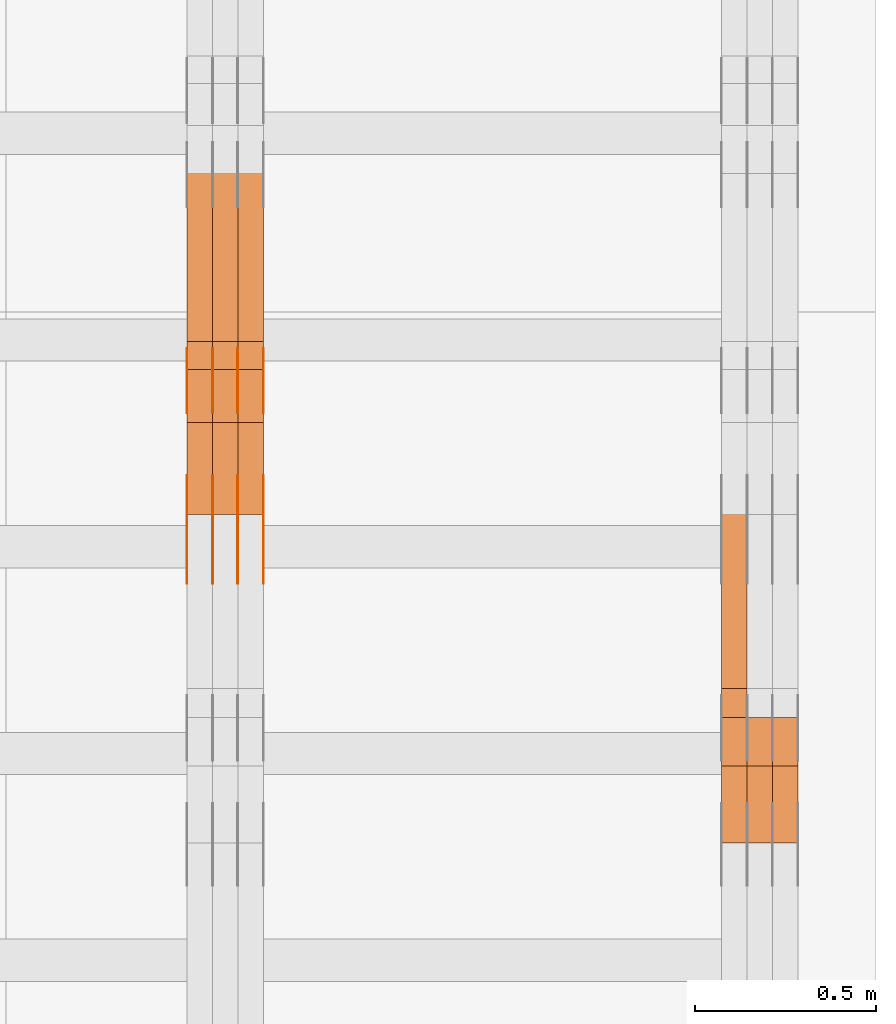
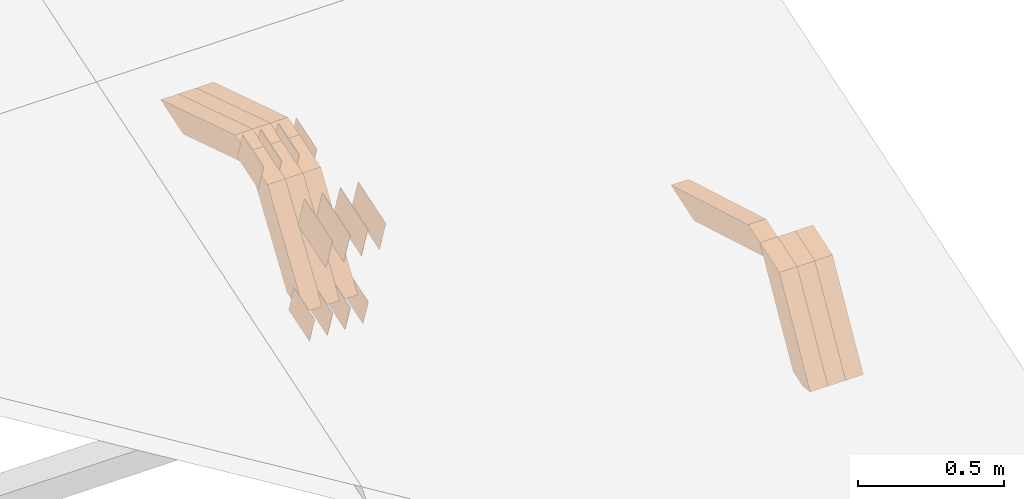
# One storey, part 309 of 385: 28 proxies.
"""IFC2X3 building model written with IfcOpenShell, lengths in millimetres."""

from ifc_helpers import new_model, entity, si_unit, converted_unit, derived_unit, direction, frame, origin, place, context, subcontext, project, spatial, polyline, outline, extrude, source, transform, mapped, material, type_object, type_shapes, element, save


model = new_model("IFC2X3")

# Units and contexts
model_context = context("Model", 3, precision=0.01, world=origin(), true_north=direction((6.12303176911189e-17, 1.0)))
body_context = subcontext(model_context, "Body", "Model", "MODEL_VIEW")
ifc_project = project(units=[si_unit("LENGTHUNIT", "METRE", prefix="MILLI"), si_unit("AREAUNIT", "SQUARE_METRE"), si_unit("VOLUMEUNIT", "CUBIC_METRE"), converted_unit("PLANEANGLEUNIT", "DEGREE", entity("IfcRatioMeasure", 0.0174532925199433), si_unit("PLANEANGLEUNIT", "RADIAN"), dimensions=[0, 0, 0, 0, 0, 0, 0]), si_unit("MASSUNIT", "GRAM", prefix="KILO"), derived_unit("MASSDENSITYUNIT", [(si_unit("MASSUNIT", "GRAM", prefix="KILO"), 1), (si_unit("LENGTHUNIT", "METRE"), -3)]), si_unit("TIMEUNIT", "SECOND"), si_unit("FREQUENCYUNIT", "HERTZ"), si_unit("THERMODYNAMICTEMPERATUREUNIT", "DEGREE_CELSIUS"), derived_unit("THERMALTRANSMITTANCEUNIT", [(si_unit("MASSUNIT", "GRAM", prefix="KILO"), 1), (si_unit("THERMODYNAMICTEMPERATUREUNIT", "KELVIN"), -1), (si_unit("TIMEUNIT", "SECOND"), -3)]), derived_unit("VOLUMETRICFLOWRATEUNIT", [(si_unit("LENGTHUNIT", "METRE"), 3), (si_unit("TIMEUNIT", "SECOND"), -1)]), si_unit("ELECTRICCURRENTUNIT", "AMPERE"), si_unit("ELECTRICVOLTAGEUNIT", "VOLT"), si_unit("POWERUNIT", "WATT"), si_unit("FORCEUNIT", "NEWTON", prefix="KILO"), si_unit("ILLUMINANCEUNIT", "LUX"), si_unit("LUMINOUSFLUXUNIT", "LUMEN"), si_unit("LUMINOUSINTENSITYUNIT", "CANDELA"), derived_unit("USERDEFINED", [(si_unit("MASSUNIT", "GRAM", prefix="KILO"), -1), (si_unit("LENGTHUNIT", "METRE"), -2), (si_unit("TIMEUNIT", "SECOND"), 3), (si_unit("LUMINOUSFLUXUNIT", "LUMEN"), 1)]), derived_unit("LINEARVELOCITYUNIT", [(si_unit("LENGTHUNIT", "METRE"), 1), (si_unit("TIMEUNIT", "SECOND"), -1)]), si_unit("PRESSUREUNIT", "PASCAL"), derived_unit("USERDEFINED", [(si_unit("LENGTHUNIT", "METRE"), -2), (si_unit("MASSUNIT", "GRAM", prefix="KILO"), 1), (si_unit("TIMEUNIT", "SECOND"), -2)])], contexts=[model_context])

# Site, building, storey
site_placement = place(None, origin())
site = spatial("IfcSite", under=ifc_project, at=site_placement, CompositionType="ELEMENT")
building_placement = place(site_placement, origin())
building = spatial("IfcBuilding", under=site, at=building_placement, CompositionType="ELEMENT")
storey_placement = place(building_placement, origin())
storey = spatial("IfcBuildingStorey", under=building, at=storey_placement, Name="Default", CompositionType="ELEMENT", Elevation=0.0)

# Proxies
ifc_material_1 = material(Name="IfcSurfaceStyle #595300")
building_element_proxy_type_1 = type_object("IfcBuildingElementProxyType", Name="T2-W12 595298", PredefinedType="NOTDEFINED", material=ifc_material_1)
shared_shape_1 = source(origin(), body_context, "Body", "SweptSolid", [
    extrude(outline(polyline([(-249.405625983165, -47.5001691155616), (243.345753908996, -47.5001691155616), (232.115534842595, 2.39993474701938e-05), (162.527010966644, 47.5001571158879), (-388.58267373507, 47.5001571158879), (-249.405625983165, -47.5001691155616)])), frame((243.345867653852, 47.5001571158879, 0.0), z_axis=(0.0, 0.0, 1.0), x_axis=(-1.0, 0.0, 0.0)), (0.0, 0.0, 1.0), 70.0),
])
type_shapes(building_element_proxy_type_1, [shared_shape_1])
proxy_1_placement = place(building_placement, frame((49720.0, 4581.32698473631, 976.172276753357), z_axis=(-1.0, 0.0, 0.0), x_axis=(0.0, 0.959722067881787, -0.280951156645966)))
element("IfcBuildingElementProxy", 1, at=proxy_1_placement, inside=storey, type_object=building_element_proxy_type_1, material=ifc_material_1, Name="T2-W12", context=body_context, shape_type="MappedRepresentation", body=[
    mapped(shared_shape_1, transform((0.0, 0.0, 0.0), scale=1.0)),
])
ifc_material_2 = material(Name="IfcSurfaceStyle #595036")
building_element_proxy_type_2 = type_object("IfcBuildingElementProxyType", Name="T2-W27 595034", PredefinedType="NOTDEFINED", material=ifc_material_2)
shared_shape_2 = source(origin(), body_context, "Body", "SweptSolid", [
    extrude(outline(polyline([(-321.979763159708, -47.49993999164), (138.960018341432, -47.49993999164), (191.013775341887, -0.000473170132329126), (209.87827169492, 47.5001765767061), (-217.872302218531, 47.5001765767062), (-321.979763159708, -47.49993999164)])), frame((209.87827169492, 47.5001765767061, 0.0), z_axis=(0.0, 0.0, 1.0), x_axis=(-1.0, 0.0, 0.0)), (0.0, 0.0, 1.0), 70.0),
])
type_shapes(building_element_proxy_type_2, [shared_shape_2])
proxy_2_placement = place(building_placement, frame((49860.0, 4233.3125, 512.021728515625), z_axis=(-1.0, 0.0, 0.0), x_axis=(0.0, 0.494231057369727, 0.869330582650352)))
element("IfcBuildingElementProxy", 2, at=proxy_2_placement, inside=storey, type_object=building_element_proxy_type_2, material=ifc_material_2, Name="T2-W27", context=body_context, shape_type="MappedRepresentation", body=[
    mapped(shared_shape_2, transform((0.0, 0.0, 0.0), scale=1.0)),
])
ifc_material_3 = material(Name="IfcSurfaceStyle #594970")
building_element_proxy_type_3 = type_object("IfcBuildingElementProxyType", Name="T2-W27 594968", PredefinedType="NOTDEFINED", material=ifc_material_3)
shared_shape_3 = source(origin(), body_context, "Body", "SweptSolid", [
    extrude(outline(polyline([(-321.979763159708, -47.49993999164), (138.960018341432, -47.49993999164), (191.013775341887, -0.000473170132329126), (209.87827169492, 47.5001765767061), (-217.872302218531, 47.5001765767062), (-321.979763159708, -47.49993999164)])), frame((209.87827169492, 47.5001765767061, 0.0), z_axis=(0.0, 0.0, 1.0), x_axis=(-1.0, 0.0, 0.0)), (0.0, 0.0, 1.0), 70.0),
])
type_shapes(building_element_proxy_type_3, [shared_shape_3])
proxy_3_placement = place(building_placement, frame((49790.0, 4233.3125, 512.021728515625), z_axis=(-1.0, 0.0, 0.0), x_axis=(0.0, 0.494231057369727, 0.869330582650352)))
element("IfcBuildingElementProxy", 3, at=proxy_3_placement, inside=storey, type_object=building_element_proxy_type_3, material=ifc_material_3, Name="T2-W27", context=body_context, shape_type="MappedRepresentation", body=[
    mapped(shared_shape_3, transform((0.0, 0.0, 0.0), scale=1.0)),
])
ifc_material_4 = material(Name="IfcSurfaceStyle #594904")
building_element_proxy_type_4 = type_object("IfcBuildingElementProxyType", Name="T2-W27 594902", PredefinedType="NOTDEFINED", material=ifc_material_4)
shared_shape_4 = source(origin(), body_context, "Body", "SweptSolid", [
    extrude(outline(polyline([(-321.979763159708, -47.49993999164), (138.960018341432, -47.49993999164), (191.013775341887, -0.000473170132329126), (209.87827169492, 47.5001765767061), (-217.872302218531, 47.5001765767062), (-321.979763159708, -47.49993999164)])), frame((209.87827169492, 47.5001765767061, 0.0), z_axis=(0.0, 0.0, 1.0), x_axis=(-1.0, 0.0, 0.0)), (0.0, 0.0, 1.0), 70.0),
])
type_shapes(building_element_proxy_type_4, [shared_shape_4])
proxy_4_placement = place(building_placement, frame((49720.0, 4233.3125, 512.021728515625), z_axis=(-1.0, 0.0, 0.0), x_axis=(0.0, 0.494231057369727, 0.869330582650352)))
element("IfcBuildingElementProxy", 4, at=proxy_4_placement, inside=storey, type_object=building_element_proxy_type_4, material=ifc_material_4, Name="T2-W27", context=body_context, shape_type="MappedRepresentation", body=[
    mapped(shared_shape_4, transform((0.0, 0.0, 0.0), scale=1.0)),
])
ifc_material_5 = material(Name="IfcSurfaceStyle #580368")
building_element_proxy_type_5 = type_object("IfcBuildingElementProxyType", PredefinedType="NOTDEFINED", material=ifc_material_5)
shared_shape_5 = source(origin(), body_context, "Body", "SweptSolid", [
    extrude(outline(polyline([(-74.9998707133927, -60.0000596852269), (74.9998841352353, -60.0000596852269), (74.999861282944, 60.0000596852269), (-74.9998747047866, 60.0000596852269), (-74.9998707133927, -60.0000596852269)])), frame((74.9998841352353, 60.0000596852269, 0.0), z_axis=(0.0, 0.0, 1.0), x_axis=(-1.0, 0.0, 0.0)), (0.0, 0.0, 1.0), 1.3),
])
type_shapes(building_element_proxy_type_5, [shared_shape_5])
proxy_5_placement = place(building_placement, frame((48386.3, 5067.4882362875, 826.131473120182), z_axis=(-1.0, 0.0, 0.0), x_axis=(0.0, 0.951056516295124, 0.309016994375039)))
element("IfcBuildingElementProxy", 5, at=proxy_5_placement, inside=storey, type_object=building_element_proxy_type_5, material=ifc_material_5, context=body_context, shape_type="MappedRepresentation", body=[
    mapped(shared_shape_5, transform((0.0, 0.0, 0.0), scale=1.0)),
])
ifc_material_6 = material(Name="IfcSurfaceStyle #580311")
building_element_proxy_type_6 = type_object("IfcBuildingElementProxyType", PredefinedType="NOTDEFINED", material=ifc_material_6)
shared_shape_6 = source(origin(), body_context, "Body", "SweptSolid", [
    extrude(outline(polyline([(-74.9998707133927, -60.0000596852269), (74.9998841352353, -60.0000596852269), (74.999861282944, 60.0000596852269), (-74.9998747047866, 60.0000596852269), (-74.9998707133927, -60.0000596852269)])), frame((74.9998841352353, 60.0000596852269, 0.0), z_axis=(0.0, 0.0, 1.0), x_axis=(-1.0, 0.0, 0.0)), (0.0, 0.0, 1.0), 1.3),
])
type_shapes(building_element_proxy_type_6, [shared_shape_6])
proxy_6_placement = place(building_placement, frame((48315.0, 5067.4882362875, 826.131473120182), z_axis=(-1.0, 0.0, 0.0), x_axis=(0.0, 0.951056516295124, 0.309016994375039)))
element("IfcBuildingElementProxy", 6, at=proxy_6_placement, inside=storey, type_object=building_element_proxy_type_6, material=ifc_material_6, context=body_context, shape_type="MappedRepresentation", body=[
    mapped(shared_shape_6, transform((0.0, 0.0, 0.0), scale=1.0)),
])
ifc_material_7 = material(Name="IfcSurfaceStyle #580254")
building_element_proxy_type_7 = type_object("IfcBuildingElementProxyType", PredefinedType="NOTDEFINED", material=ifc_material_7)
shared_shape_7 = source(origin(), body_context, "Body", "SweptSolid", [
    extrude(outline(polyline([(-74.9998707133927, -60.0000596852269), (74.9998841352353, -60.0000596852269), (74.999861282944, 60.0000596852269), (-74.9998747047866, 60.0000596852269), (-74.9998707133927, -60.0000596852269)])), frame((74.9998841352353, 60.0000596852269, 0.0), z_axis=(0.0, 0.0, 1.0), x_axis=(-1.0, 0.0, 0.0)), (0.0, 0.0, 1.0), 1.3),
])
type_shapes(building_element_proxy_type_7, [shared_shape_7])
proxy_7_placement = place(building_placement, frame((48316.3, 5067.4882362875, 826.131473120182), z_axis=(-1.0, 0.0, 0.0), x_axis=(0.0, 0.951056516295124, 0.309016994375039)))
element("IfcBuildingElementProxy", 7, at=proxy_7_placement, inside=storey, type_object=building_element_proxy_type_7, material=ifc_material_7, context=body_context, shape_type="MappedRepresentation", body=[
    mapped(shared_shape_7, transform((0.0, 0.0, 0.0), scale=1.0)),
])
ifc_material_8 = material(Name="IfcSurfaceStyle #580197")
building_element_proxy_type_8 = type_object("IfcBuildingElementProxyType", PredefinedType="NOTDEFINED", material=ifc_material_8)
shared_shape_8 = source(origin(), body_context, "Body", "SweptSolid", [
    extrude(outline(polyline([(-74.9998707133927, -60.0000596852269), (74.9998841352353, -60.0000596852269), (74.999861282944, 60.0000596852269), (-74.9998747047866, 60.0000596852269), (-74.9998707133927, -60.0000596852269)])), frame((74.9998841352353, 60.0000596852269, 0.0), z_axis=(0.0, 0.0, 1.0), x_axis=(-1.0, 0.0, 0.0)), (0.0, 0.0, 1.0), 1.29999999999999),
])
type_shapes(building_element_proxy_type_8, [shared_shape_8])
proxy_8_placement = place(building_placement, frame((48245.0, 5067.4882362875, 826.131473120182), z_axis=(-1.0, 0.0, 0.0), x_axis=(0.0, 0.951056516295124, 0.309016994375039)))
element("IfcBuildingElementProxy", 8, at=proxy_8_placement, inside=storey, type_object=building_element_proxy_type_8, material=ifc_material_8, context=body_context, shape_type="MappedRepresentation", body=[
    mapped(shared_shape_8, transform((0.0, 0.0, 0.0), scale=1.0)),
])
ifc_material_9 = material(Name="IfcSurfaceStyle #580140")
building_element_proxy_type_9 = type_object("IfcBuildingElementProxyType", PredefinedType="NOTDEFINED", material=ifc_material_9)
shared_shape_9 = source(origin(), body_context, "Body", "SweptSolid", [
    extrude(outline(polyline([(-74.9998707133927, -60.0000596852269), (74.9998841352353, -60.0000596852269), (74.999861282944, 60.0000596852269), (-74.9998747047866, 60.0000596852269), (-74.9998707133927, -60.0000596852269)])), frame((74.9998841352353, 60.0000596852269, 0.0), z_axis=(0.0, 0.0, 1.0), x_axis=(-1.0, 0.0, 0.0)), (0.0, 0.0, 1.0), 1.29999999999999),
])
type_shapes(building_element_proxy_type_9, [shared_shape_9])
proxy_9_placement = place(building_placement, frame((48246.3, 5067.4882362875, 826.131473120182), z_axis=(-1.0, 0.0, 0.0), x_axis=(0.0, 0.951056516295124, 0.309016994375039)))
element("IfcBuildingElementProxy", 9, at=proxy_9_placement, inside=storey, type_object=building_element_proxy_type_9, material=ifc_material_9, context=body_context, shape_type="MappedRepresentation", body=[
    mapped(shared_shape_9, transform((0.0, 0.0, 0.0), scale=1.0)),
])
ifc_material_10 = material(Name="IfcSurfaceStyle #580083")
building_element_proxy_type_10 = type_object("IfcBuildingElementProxyType", PredefinedType="NOTDEFINED", material=ifc_material_10)
shared_shape_10 = source(origin(), body_context, "Body", "SweptSolid", [
    extrude(outline(polyline([(-74.9998707133927, -60.0000596852269), (74.9998841352353, -60.0000596852269), (74.999861282944, 60.0000596852269), (-74.9998747047866, 60.0000596852269), (-74.9998707133927, -60.0000596852269)])), frame((74.9998841352353, 60.0000596852269, 0.0), z_axis=(0.0, 0.0, 1.0), x_axis=(-1.0, 0.0, 0.0)), (0.0, 0.0, 1.0), 1.29999999999999),
])
type_shapes(building_element_proxy_type_10, [shared_shape_10])
proxy_10_placement = place(building_placement, frame((48175.0, 5067.4882362875, 826.131473120182), z_axis=(-1.0, 0.0, 0.0), x_axis=(0.0, 0.951056516295124, 0.309016994375039)))
element("IfcBuildingElementProxy", 10, at=proxy_10_placement, inside=storey, type_object=building_element_proxy_type_10, material=ifc_material_10, context=body_context, shape_type="MappedRepresentation", body=[
    mapped(shared_shape_10, transform((0.0, 0.0, 0.0), scale=1.0)),
])
ifc_material_11 = material(Name="IfcSurfaceStyle #574554")
building_element_proxy_type_11 = type_object("IfcBuildingElementProxyType", PredefinedType="NOTDEFINED", material=ifc_material_11)
shared_shape_11 = source(origin(), body_context, "Body", "SweptSolid", [
    extrude(outline(polyline([(-74.9998565677224, -60.0000596852342), (74.9998794200083, -60.0000596852342), (74.9998565677242, 60.0000596852342), (-74.9998794200101, 60.0000596852342), (-74.9998565677224, -60.0000596852342)])), frame((74.9998794200083, 60.0000596852342, 0.0), z_axis=(0.0, 0.0, 1.0), x_axis=(-1.0, 0.0, 0.0)), (0.0, 0.0, 1.0), 1.3),
])
type_shapes(building_element_proxy_type_11, [shared_shape_11])
proxy_11_placement = place(building_placement, frame((48386.3, 5418.69917378751, 1250.81341892098), z_axis=(-1.0, 0.0, 0.0), x_axis=(0.0, 0.951056516295154, 0.309016994374948)))
element("IfcBuildingElementProxy", 11, at=proxy_11_placement, inside=storey, type_object=building_element_proxy_type_11, material=ifc_material_11, context=body_context, shape_type="MappedRepresentation", body=[
    mapped(shared_shape_11, transform((0.0, 0.0, 0.0), scale=1.0)),
])
ifc_material_12 = material(Name="IfcSurfaceStyle #574497")
building_element_proxy_type_12 = type_object("IfcBuildingElementProxyType", PredefinedType="NOTDEFINED", material=ifc_material_12)
shared_shape_12 = source(origin(), body_context, "Body", "SweptSolid", [
    extrude(outline(polyline([(-74.9998565677224, -60.0000596852342), (74.9998794200083, -60.0000596852342), (74.9998565677242, 60.0000596852342), (-74.9998794200101, 60.0000596852342), (-74.9998565677224, -60.0000596852342)])), frame((74.9998794200083, 60.0000596852342, 0.0), z_axis=(0.0, 0.0, 1.0), x_axis=(-1.0, 0.0, 0.0)), (0.0, 0.0, 1.0), 1.3),
])
type_shapes(building_element_proxy_type_12, [shared_shape_12])
proxy_12_placement = place(building_placement, frame((48315.0, 5418.69917378751, 1250.81341892098), z_axis=(-1.0, 0.0, 0.0), x_axis=(0.0, 0.951056516295154, 0.309016994374948)))
element("IfcBuildingElementProxy", 12, at=proxy_12_placement, inside=storey, type_object=building_element_proxy_type_12, material=ifc_material_12, context=body_context, shape_type="MappedRepresentation", body=[
    mapped(shared_shape_12, transform((0.0, 0.0, 0.0), scale=1.0)),
])
ifc_material_13 = material(Name="IfcSurfaceStyle #574440")
building_element_proxy_type_13 = type_object("IfcBuildingElementProxyType", PredefinedType="NOTDEFINED", material=ifc_material_13)
shared_shape_13 = source(origin(), body_context, "Body", "SweptSolid", [
    extrude(outline(polyline([(-74.9998565677224, -60.0000596852342), (74.9998794200083, -60.0000596852342), (74.9998565677242, 60.0000596852342), (-74.9998794200101, 60.0000596852342), (-74.9998565677224, -60.0000596852342)])), frame((74.9998794200083, 60.0000596852342, 0.0), z_axis=(0.0, 0.0, 1.0), x_axis=(-1.0, 0.0, 0.0)), (0.0, 0.0, 1.0), 1.3),
])
type_shapes(building_element_proxy_type_13, [shared_shape_13])
proxy_13_placement = place(building_placement, frame((48316.3, 5418.69917378751, 1250.81341892098), z_axis=(-1.0, 0.0, 0.0), x_axis=(0.0, 0.951056516295154, 0.309016994374948)))
element("IfcBuildingElementProxy", 13, at=proxy_13_placement, inside=storey, type_object=building_element_proxy_type_13, material=ifc_material_13, context=body_context, shape_type="MappedRepresentation", body=[
    mapped(shared_shape_13, transform((0.0, 0.0, 0.0), scale=1.0)),
])
ifc_material_14 = material(Name="IfcSurfaceStyle #574383")
building_element_proxy_type_14 = type_object("IfcBuildingElementProxyType", PredefinedType="NOTDEFINED", material=ifc_material_14)
shared_shape_14 = source(origin(), body_context, "Body", "SweptSolid", [
    extrude(outline(polyline([(-74.9998565677224, -60.0000596852342), (74.9998794200083, -60.0000596852342), (74.9998565677242, 60.0000596852342), (-74.9998794200101, 60.0000596852342), (-74.9998565677224, -60.0000596852342)])), frame((74.9998794200083, 60.0000596852342, 0.0), z_axis=(0.0, 0.0, 1.0), x_axis=(-1.0, 0.0, 0.0)), (0.0, 0.0, 1.0), 1.29999999999999),
])
type_shapes(building_element_proxy_type_14, [shared_shape_14])
proxy_14_placement = place(building_placement, frame((48245.0, 5418.69917378751, 1250.81341892098), z_axis=(-1.0, 0.0, 0.0), x_axis=(0.0, 0.951056516295154, 0.309016994374948)))
element("IfcBuildingElementProxy", 14, at=proxy_14_placement, inside=storey, type_object=building_element_proxy_type_14, material=ifc_material_14, context=body_context, shape_type="MappedRepresentation", body=[
    mapped(shared_shape_14, transform((0.0, 0.0, 0.0), scale=1.0)),
])
ifc_material_15 = material(Name="IfcSurfaceStyle #574326")
building_element_proxy_type_15 = type_object("IfcBuildingElementProxyType", PredefinedType="NOTDEFINED", material=ifc_material_15)
shared_shape_15 = source(origin(), body_context, "Body", "SweptSolid", [
    extrude(outline(polyline([(-74.9998565677224, -60.0000596852342), (74.9998794200083, -60.0000596852342), (74.9998565677242, 60.0000596852342), (-74.9998794200101, 60.0000596852342), (-74.9998565677224, -60.0000596852342)])), frame((74.9998794200083, 60.0000596852342, 0.0), z_axis=(0.0, 0.0, 1.0), x_axis=(-1.0, 0.0, 0.0)), (0.0, 0.0, 1.0), 1.29999999999999),
])
type_shapes(building_element_proxy_type_15, [shared_shape_15])
proxy_15_placement = place(building_placement, frame((48246.3, 5418.69917378751, 1250.81341892098), z_axis=(-1.0, 0.0, 0.0), x_axis=(0.0, 0.951056516295154, 0.309016994374948)))
element("IfcBuildingElementProxy", 15, at=proxy_15_placement, inside=storey, type_object=building_element_proxy_type_15, material=ifc_material_15, context=body_context, shape_type="MappedRepresentation", body=[
    mapped(shared_shape_15, transform((0.0, 0.0, 0.0), scale=1.0)),
])
ifc_material_16 = material(Name="IfcSurfaceStyle #574269")
building_element_proxy_type_16 = type_object("IfcBuildingElementProxyType", PredefinedType="NOTDEFINED", material=ifc_material_16)
shared_shape_16 = source(origin(), body_context, "Body", "SweptSolid", [
    extrude(outline(polyline([(-74.9998565677224, -60.0000596852342), (74.9998794200083, -60.0000596852342), (74.9998565677242, 60.0000596852342), (-74.9998794200101, 60.0000596852342), (-74.9998565677224, -60.0000596852342)])), frame((74.9998794200083, 60.0000596852342, 0.0), z_axis=(0.0, 0.0, 1.0), x_axis=(-1.0, 0.0, 0.0)), (0.0, 0.0, 1.0), 1.29999999999999),
])
type_shapes(building_element_proxy_type_16, [shared_shape_16])
proxy_16_placement = place(building_placement, frame((48175.0, 5418.69917378751, 1250.81341892098), z_axis=(-1.0, 0.0, 0.0), x_axis=(0.0, 0.951056516295154, 0.309016994374948)))
element("IfcBuildingElementProxy", 16, at=proxy_16_placement, inside=storey, type_object=building_element_proxy_type_16, material=ifc_material_16, context=body_context, shape_type="MappedRepresentation", body=[
    mapped(shared_shape_16, transform((0.0, 0.0, 0.0), scale=1.0)),
])
ifc_material_17 = material(Name="IfcSurfaceStyle #571134")
building_element_proxy_type_17 = type_object("IfcBuildingElementProxyType", PredefinedType="NOTDEFINED", material=ifc_material_17)
shared_shape_17 = source(origin(), body_context, "Body", "SweptSolid", [
    extrude(outline(polyline([(-99.9996257846169, -71.999973710258), (100.000009625089, -71.999973710258), (99.9996257846187, 71.999973710258), (-100.000009625091, 71.999973710258), (-99.9996257846169, -71.999973710258)])), frame((100.000083496635, 72.0000008245779, 0.0), z_axis=(0.0, 0.0, 1.0), x_axis=(-1.0, 0.0, 0.0)), (0.0, 0.0, 1.0), 1.3),
])
type_shapes(building_element_proxy_type_17, [shared_shape_17])
proxy_17_placement = place(building_placement, frame((48386.3, 4947.73195917317, 1225.53937157357), z_axis=(-1.0, 0.0, 0.0), x_axis=(0.0, 0.951056516295154, 0.309016994374948)))
element("IfcBuildingElementProxy", 17, at=proxy_17_placement, inside=storey, type_object=building_element_proxy_type_17, material=ifc_material_17, context=body_context, shape_type="MappedRepresentation", body=[
    mapped(shared_shape_17, transform((0.0, 0.0, 0.0), scale=1.0)),
])
ifc_material_18 = material(Name="IfcSurfaceStyle #571077")
building_element_proxy_type_18 = type_object("IfcBuildingElementProxyType", PredefinedType="NOTDEFINED", material=ifc_material_18)
shared_shape_18 = source(origin(), body_context, "Body", "SweptSolid", [
    extrude(outline(polyline([(-99.9996257846169, -71.999973710258), (100.000009625089, -71.999973710258), (99.9996257846187, 71.999973710258), (-100.000009625091, 71.999973710258), (-99.9996257846169, -71.999973710258)])), frame((100.000083496635, 72.0000008245779, 0.0), z_axis=(0.0, 0.0, 1.0), x_axis=(-1.0, 0.0, 0.0)), (0.0, 0.0, 1.0), 1.3),
])
type_shapes(building_element_proxy_type_18, [shared_shape_18])
proxy_18_placement = place(building_placement, frame((48315.0, 4947.73195917317, 1225.53937157357), z_axis=(-1.0, 0.0, 0.0), x_axis=(0.0, 0.951056516295154, 0.309016994374948)))
element("IfcBuildingElementProxy", 18, at=proxy_18_placement, inside=storey, type_object=building_element_proxy_type_18, material=ifc_material_18, context=body_context, shape_type="MappedRepresentation", body=[
    mapped(shared_shape_18, transform((0.0, 0.0, 0.0), scale=1.0)),
])
ifc_material_19 = material(Name="IfcSurfaceStyle #571020")
building_element_proxy_type_19 = type_object("IfcBuildingElementProxyType", PredefinedType="NOTDEFINED", material=ifc_material_19)
shared_shape_19 = source(origin(), body_context, "Body", "SweptSolid", [
    extrude(outline(polyline([(-99.9996257846169, -71.999973710258), (100.000009625089, -71.999973710258), (99.9996257846187, 71.999973710258), (-100.000009625091, 71.999973710258), (-99.9996257846169, -71.999973710258)])), frame((100.000083496635, 72.0000008245779, 0.0), z_axis=(0.0, 0.0, 1.0), x_axis=(-1.0, 0.0, 0.0)), (0.0, 0.0, 1.0), 1.3),
])
type_shapes(building_element_proxy_type_19, [shared_shape_19])
proxy_19_placement = place(building_placement, frame((48316.3, 4947.73195917317, 1225.53937157357), z_axis=(-1.0, 0.0, 0.0), x_axis=(0.0, 0.951056516295154, 0.309016994374948)))
element("IfcBuildingElementProxy", 19, at=proxy_19_placement, inside=storey, type_object=building_element_proxy_type_19, material=ifc_material_19, context=body_context, shape_type="MappedRepresentation", body=[
    mapped(shared_shape_19, transform((0.0, 0.0, 0.0), scale=1.0)),
])
ifc_material_20 = material(Name="IfcSurfaceStyle #570963")
building_element_proxy_type_20 = type_object("IfcBuildingElementProxyType", PredefinedType="NOTDEFINED", material=ifc_material_20)
shared_shape_20 = source(origin(), body_context, "Body", "SweptSolid", [
    extrude(outline(polyline([(-99.9996257846169, -71.999973710258), (100.000009625089, -71.999973710258), (99.9996257846187, 71.999973710258), (-100.000009625091, 71.999973710258), (-99.9996257846169, -71.999973710258)])), frame((100.000083496635, 72.0000008245779, 0.0), z_axis=(0.0, 0.0, 1.0), x_axis=(-1.0, 0.0, 0.0)), (0.0, 0.0, 1.0), 1.29999999999998),
])
type_shapes(building_element_proxy_type_20, [shared_shape_20])
proxy_20_placement = place(building_placement, frame((48245.0, 4947.73195917317, 1225.53937157357), z_axis=(-1.0, 0.0, 0.0), x_axis=(0.0, 0.951056516295154, 0.309016994374948)))
element("IfcBuildingElementProxy", 20, at=proxy_20_placement, inside=storey, type_object=building_element_proxy_type_20, material=ifc_material_20, context=body_context, shape_type="MappedRepresentation", body=[
    mapped(shared_shape_20, transform((0.0, 0.0, 0.0), scale=1.0)),
])
ifc_material_21 = material(Name="IfcSurfaceStyle #570906")
building_element_proxy_type_21 = type_object("IfcBuildingElementProxyType", PredefinedType="NOTDEFINED", material=ifc_material_21)
shared_shape_21 = source(origin(), body_context, "Body", "SweptSolid", [
    extrude(outline(polyline([(-99.9996257846169, -71.999973710258), (100.000009625089, -71.999973710258), (99.9996257846187, 71.999973710258), (-100.000009625091, 71.999973710258), (-99.9996257846169, -71.999973710258)])), frame((100.000083496635, 72.0000008245779, 0.0), z_axis=(0.0, 0.0, 1.0), x_axis=(-1.0, 0.0, 0.0)), (0.0, 0.0, 1.0), 1.29999999999998),
])
type_shapes(building_element_proxy_type_21, [shared_shape_21])
proxy_21_placement = place(building_placement, frame((48246.3, 4947.73195917317, 1225.53937157357), z_axis=(-1.0, 0.0, 0.0), x_axis=(0.0, 0.951056516295154, 0.309016994374948)))
element("IfcBuildingElementProxy", 21, at=proxy_21_placement, inside=storey, type_object=building_element_proxy_type_21, material=ifc_material_21, context=body_context, shape_type="MappedRepresentation", body=[
    mapped(shared_shape_21, transform((0.0, 0.0, 0.0), scale=1.0)),
])
ifc_material_22 = material(Name="IfcSurfaceStyle #570849")
building_element_proxy_type_22 = type_object("IfcBuildingElementProxyType", PredefinedType="NOTDEFINED", material=ifc_material_22)
shared_shape_22 = source(origin(), body_context, "Body", "SweptSolid", [
    extrude(outline(polyline([(-99.9996257846169, -71.999973710258), (100.000009625089, -71.999973710258), (99.9996257846187, 71.999973710258), (-100.000009625091, 71.999973710258), (-99.9996257846169, -71.999973710258)])), frame((100.000083496635, 72.0000008245779, 0.0), z_axis=(0.0, 0.0, 1.0), x_axis=(-1.0, 0.0, 0.0)), (0.0, 0.0, 1.0), 1.29999999999999),
])
type_shapes(building_element_proxy_type_22, [shared_shape_22])
proxy_22_placement = place(building_placement, frame((48175.0, 4947.73195917317, 1225.53937157357), z_axis=(-1.0, 0.0, 0.0), x_axis=(0.0, 0.951056516295154, 0.309016994374948)))
element("IfcBuildingElementProxy", 22, at=proxy_22_placement, inside=storey, type_object=building_element_proxy_type_22, material=ifc_material_22, context=body_context, shape_type="MappedRepresentation", body=[
    mapped(shared_shape_22, transform((0.0, 0.0, 0.0), scale=1.0)),
])
ifc_material_23 = material(Name="IfcSurfaceStyle #561792")
building_element_proxy_type_23 = type_object("IfcBuildingElementProxyType", Name="T1-W15 561790", PredefinedType="NOTDEFINED", material=ifc_material_23)
shared_shape_23 = source(origin(), body_context, "Body", "SweptSolid", [
    extrude(outline(polyline([(-243.398341390642, -47.5000170814535), (237.775741169608, -47.5000170814535), (224.054017709933, 0.000127777485579883), (157.692261395711, 47.4999531927108), (-376.12367888461, 47.4999531927107), (-243.398341390642, -47.5000170814535)])), frame((237.77637044506, 47.5003404768297, 0.0), z_axis=(0.0, 0.0, 1.0), x_axis=(-1.0, 0.0, 0.0)), (0.0, 0.0, 1.0), 70.0),
])
type_shapes(building_element_proxy_type_23, [shared_shape_23])
proxy_23_placement = place(building_placement, frame((48385.0, 5540.23242178143, 1288.84274826279), z_axis=(-1.0, 0.0, 0.0), x_axis=(0.0, 0.95322291386448, -0.302268219440466)))
element("IfcBuildingElementProxy", 23, at=proxy_23_placement, inside=storey, type_object=building_element_proxy_type_23, material=ifc_material_23, Name="T1-W15", context=body_context, shape_type="MappedRepresentation", body=[
    mapped(shared_shape_23, transform((0.0, 0.0, 0.0), scale=1.0)),
])
ifc_material_24 = material(Name="IfcSurfaceStyle #561726")
building_element_proxy_type_24 = type_object("IfcBuildingElementProxyType", Name="T1-W15 561724", PredefinedType="NOTDEFINED", material=ifc_material_24)
shared_shape_24 = source(origin(), body_context, "Body", "SweptSolid", [
    extrude(outline(polyline([(-243.398341390642, -47.5000170814535), (237.775741169608, -47.5000170814535), (224.054017709933, 0.000127777485579883), (157.692261395711, 47.4999531927108), (-376.12367888461, 47.4999531927107), (-243.398341390642, -47.5000170814535)])), frame((237.77637044506, 47.5003404768297, 0.0), z_axis=(0.0, 0.0, 1.0), x_axis=(-1.0, 0.0, 0.0)), (0.0, 0.0, 1.0), 70.0),
])
type_shapes(building_element_proxy_type_24, [shared_shape_24])
proxy_24_placement = place(building_placement, frame((48315.0, 5540.23242178143, 1288.84274826279), z_axis=(-1.0, 0.0, 0.0), x_axis=(0.0, 0.95322291386448, -0.302268219440466)))
element("IfcBuildingElementProxy", 24, at=proxy_24_placement, inside=storey, type_object=building_element_proxy_type_24, material=ifc_material_24, Name="T1-W15", context=body_context, shape_type="MappedRepresentation", body=[
    mapped(shared_shape_24, transform((0.0, 0.0, 0.0), scale=1.0)),
])
ifc_material_25 = material(Name="IfcSurfaceStyle #561660")
building_element_proxy_type_25 = type_object("IfcBuildingElementProxyType", Name="T1-W15 561658", PredefinedType="NOTDEFINED", material=ifc_material_25)
shared_shape_25 = source(origin(), body_context, "Body", "SweptSolid", [
    extrude(outline(polyline([(-243.398341390642, -47.5000170814535), (237.775741169608, -47.5000170814535), (224.054017709933, 0.000127777485579883), (157.692261395711, 47.4999531927108), (-376.12367888461, 47.4999531927107), (-243.398341390642, -47.5000170814535)])), frame((237.77637044506, 47.5003404768297, 0.0), z_axis=(0.0, 0.0, 1.0), x_axis=(-1.0, 0.0, 0.0)), (0.0, 0.0, 1.0), 70.0),
])
type_shapes(building_element_proxy_type_25, [shared_shape_25])
proxy_25_placement = place(building_placement, frame((48245.0, 5540.23242178143, 1288.84274826279), z_axis=(-1.0, 0.0, 0.0), x_axis=(0.0, 0.95322291386448, -0.302268219440466)))
element("IfcBuildingElementProxy", 25, at=proxy_25_placement, inside=storey, type_object=building_element_proxy_type_25, material=ifc_material_25, Name="T1-W15", context=body_context, shape_type="MappedRepresentation", body=[
    mapped(shared_shape_25, transform((0.0, 0.0, 0.0), scale=1.0)),
])
ifc_material_26 = material(Name="IfcSurfaceStyle #561396")
building_element_proxy_type_26 = type_object("IfcBuildingElementProxyType", Name="T1-W22 561394", PredefinedType="NOTDEFINED", material=ifc_material_26)
shared_shape_26 = source(origin(), body_context, "Body", "SweptSolid", [
    extrude(outline(polyline([(-351.940486061686, -47.5005995570677), (149.451602529695, -47.5005995570676), (209.614029773051, 0.000108554198836676), (224.491670779786, 47.5010029530092), (-231.616817020846, 47.5000876069273), (-351.940486061686, -47.5005995570677)])), frame((224.491766107217, 47.5005524294596, 0.0), z_axis=(0.0, 0.0, 1.0), x_axis=(-1.0, 2.00686044286885e-06, 0.0)), (0.0, 0.0, 1.0), 70.0),
])
type_shapes(building_element_proxy_type_26, [shared_shape_26])
proxy_26_placement = place(building_placement, frame((48385.0, 5140.03125000001, 812.615600585936), z_axis=(-1.0, 0.0, 0.0), x_axis=(0.0, 0.554956576676696, 0.831879316970486)))
element("IfcBuildingElementProxy", 26, at=proxy_26_placement, inside=storey, type_object=building_element_proxy_type_26, material=ifc_material_26, Name="T1-W22", context=body_context, shape_type="MappedRepresentation", body=[
    mapped(shared_shape_26, transform((0.0, 0.0, 0.0), scale=1.0)),
])
ifc_material_27 = material(Name="IfcSurfaceStyle #561330")
building_element_proxy_type_27 = type_object("IfcBuildingElementProxyType", Name="T1-W22 561328", PredefinedType="NOTDEFINED", material=ifc_material_27)
shared_shape_27 = source(origin(), body_context, "Body", "SweptSolid", [
    extrude(outline(polyline([(-351.940486061686, -47.5005995570677), (149.451602529695, -47.5005995570676), (209.614029773051, 0.000108554198836676), (224.491670779786, 47.5010029530092), (-231.616817020846, 47.5000876069273), (-351.940486061686, -47.5005995570677)])), frame((224.491766107217, 47.5005524294596, 0.0), z_axis=(0.0, 0.0, 1.0), x_axis=(-1.0, 2.00686044286885e-06, 0.0)), (0.0, 0.0, 1.0), 70.0),
])
type_shapes(building_element_proxy_type_27, [shared_shape_27])
proxy_27_placement = place(building_placement, frame((48315.0, 5140.03125000001, 812.615600585936), z_axis=(-1.0, 0.0, 0.0), x_axis=(0.0, 0.554956576676696, 0.831879316970486)))
element("IfcBuildingElementProxy", 27, at=proxy_27_placement, inside=storey, type_object=building_element_proxy_type_27, material=ifc_material_27, Name="T1-W22", context=body_context, shape_type="MappedRepresentation", body=[
    mapped(shared_shape_27, transform((0.0, 0.0, 0.0), scale=1.0)),
])
ifc_material_28 = material(Name="IfcSurfaceStyle #561264")
building_element_proxy_type_28 = type_object("IfcBuildingElementProxyType", Name="T1-W22 561262", PredefinedType="NOTDEFINED", material=ifc_material_28)
shared_shape_28 = source(origin(), body_context, "Body", "SweptSolid", [
    extrude(outline(polyline([(-351.940486061686, -47.5005995570677), (149.451602529695, -47.5005995570676), (209.614029773051, 0.000108554198836676), (224.491670779786, 47.5010029530092), (-231.616817020846, 47.5000876069273), (-351.940486061686, -47.5005995570677)])), frame((224.491766107217, 47.5005524294596, 0.0), z_axis=(0.0, 0.0, 1.0), x_axis=(-1.0, 2.00686044286885e-06, 0.0)), (0.0, 0.0, 1.0), 70.0),
])
type_shapes(building_element_proxy_type_28, [shared_shape_28])
proxy_28_placement = place(building_placement, frame((48245.0, 5140.03125000001, 812.615600585936), z_axis=(-1.0, 0.0, 0.0), x_axis=(0.0, 0.554956576676696, 0.831879316970486)))
element("IfcBuildingElementProxy", 28, at=proxy_28_placement, inside=storey, type_object=building_element_proxy_type_28, material=ifc_material_28, Name="T1-W22", context=body_context, shape_type="MappedRepresentation", body=[
    mapped(shared_shape_28, transform((0.0, 0.0, 0.0), scale=1.0)),
])

save(model, "model.ifc")
